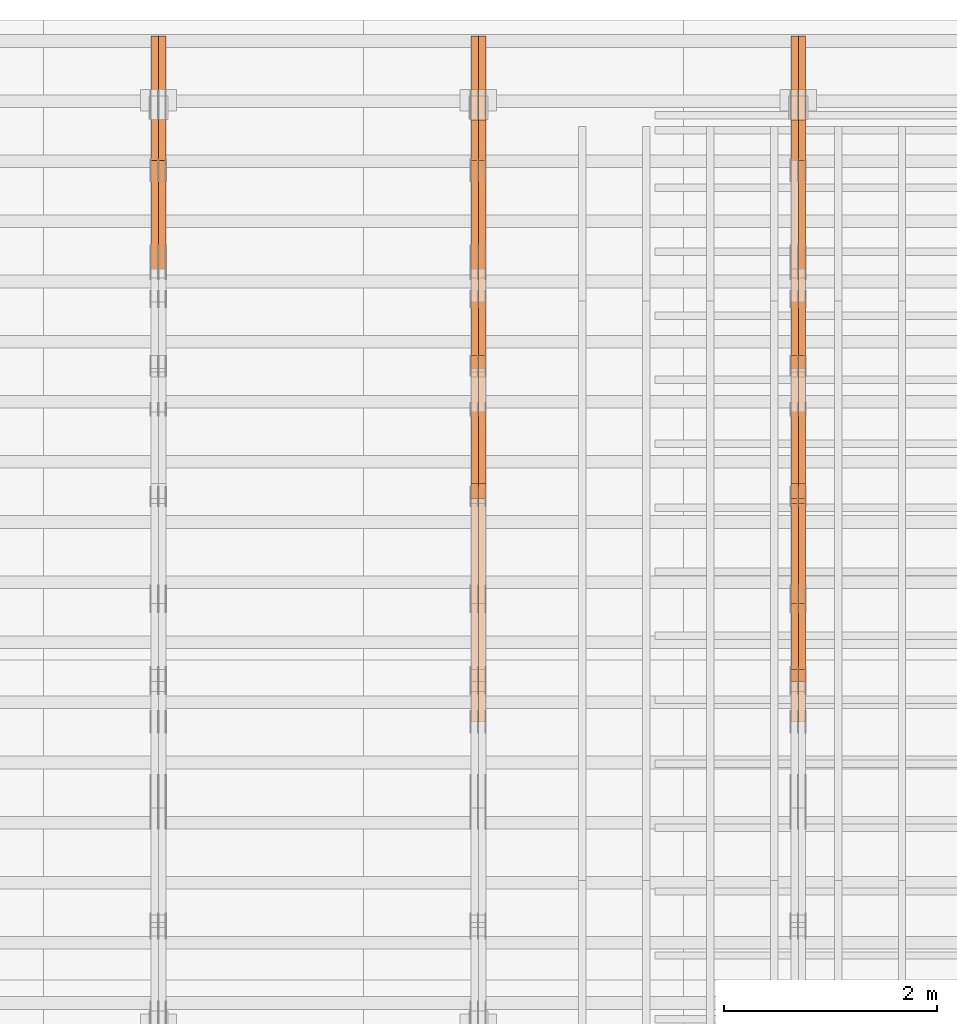
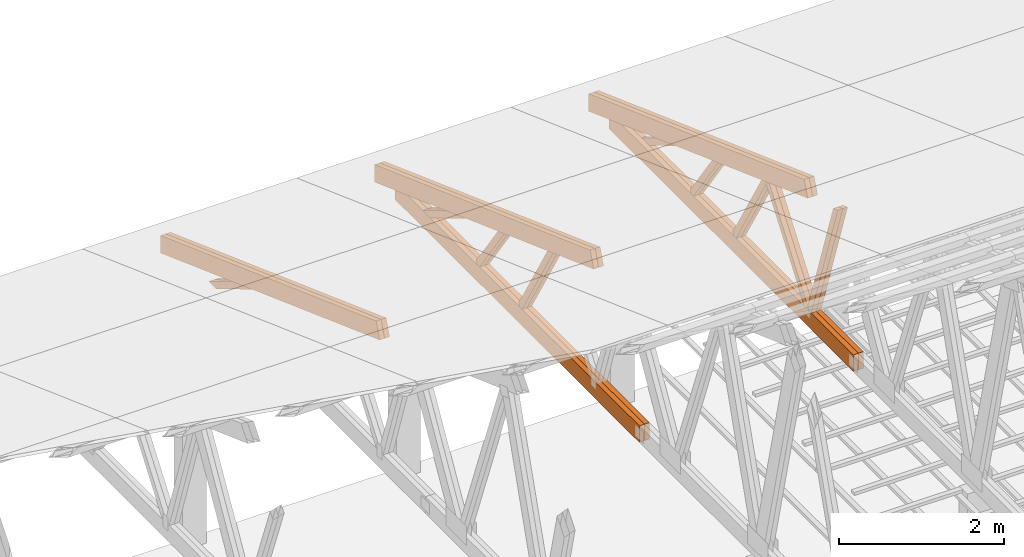
# One storey, part 63 of 189: 27 proxies.
"""IFC2X3 building model written with IfcOpenShell, lengths in millimetres."""

from ifc_helpers import new_model, entity, si_unit, converted_unit, derived_unit, direction, frame, origin, place, context, subcontext, project, spatial, polyline, outline, extrude, source, transform, mapped, material, type_object, type_shapes, element, save


model = new_model("IFC2X3")

# Units and contexts
model_context = context("Model", 3, precision=0.01, world=origin(), true_north=direction((6.12303176911189e-17, 1.0)))
body_context = subcontext(model_context, "Body", "Model", "MODEL_VIEW")
ifc_project = project(units=[si_unit("LENGTHUNIT", "METRE", prefix="MILLI"), si_unit("AREAUNIT", "SQUARE_METRE"), si_unit("VOLUMEUNIT", "CUBIC_METRE"), converted_unit("PLANEANGLEUNIT", "DEGREE", entity("IfcRatioMeasure", 0.0174532925199433), si_unit("PLANEANGLEUNIT", "RADIAN"), dimensions=[0, 0, 0, 0, 0, 0, 0]), si_unit("MASSUNIT", "GRAM", prefix="KILO"), derived_unit("MASSDENSITYUNIT", [(si_unit("MASSUNIT", "GRAM", prefix="KILO"), 1), (si_unit("LENGTHUNIT", "METRE"), -3)]), si_unit("TIMEUNIT", "SECOND"), si_unit("FREQUENCYUNIT", "HERTZ"), si_unit("THERMODYNAMICTEMPERATUREUNIT", "DEGREE_CELSIUS"), derived_unit("THERMALTRANSMITTANCEUNIT", [(si_unit("MASSUNIT", "GRAM", prefix="KILO"), 1), (si_unit("THERMODYNAMICTEMPERATUREUNIT", "KELVIN"), -1), (si_unit("TIMEUNIT", "SECOND"), -3)]), derived_unit("VOLUMETRICFLOWRATEUNIT", [(si_unit("LENGTHUNIT", "METRE"), 3), (si_unit("TIMEUNIT", "SECOND"), -1)]), si_unit("ELECTRICCURRENTUNIT", "AMPERE"), si_unit("ELECTRICVOLTAGEUNIT", "VOLT"), si_unit("POWERUNIT", "WATT"), si_unit("FORCEUNIT", "NEWTON"), si_unit("ILLUMINANCEUNIT", "LUX"), si_unit("LUMINOUSFLUXUNIT", "LUMEN"), si_unit("LUMINOUSINTENSITYUNIT", "CANDELA"), derived_unit("USERDEFINED", [(si_unit("MASSUNIT", "GRAM", prefix="KILO"), -1), (si_unit("LENGTHUNIT", "METRE"), -2), (si_unit("TIMEUNIT", "SECOND"), 3), (si_unit("LUMINOUSFLUXUNIT", "LUMEN"), 1)]), derived_unit("LINEARVELOCITYUNIT", [(si_unit("LENGTHUNIT", "METRE"), 1), (si_unit("TIMEUNIT", "SECOND"), -1)]), si_unit("PRESSUREUNIT", "PASCAL"), derived_unit("USERDEFINED", [(si_unit("LENGTHUNIT", "METRE"), -2), (si_unit("MASSUNIT", "GRAM", prefix="KILO"), 1), (si_unit("TIMEUNIT", "SECOND"), -2)])], contexts=[model_context])

# Site, building, storey
site_placement = place(None, origin())
site = spatial("IfcSite", under=ifc_project, at=site_placement, CompositionType="ELEMENT")
building_placement = place(site_placement, origin())
building = spatial("IfcBuilding", under=site, at=building_placement, CompositionType="ELEMENT")
storey_placement = place(building_placement, origin())
storey = spatial("IfcBuildingStorey", under=building, at=storey_placement, Name="Default", CompositionType="ELEMENT", Elevation=0.0)

# Proxies
ifc_material_1 = material(Name="IfcSurfaceStyle #240080")
building_element_proxy_type_1 = type_object("IfcBuildingElementProxyType", Name="T1-W9 240078", PredefinedType="NOTDEFINED", material=ifc_material_1)
shared_shape_1 = source(origin(), body_context, "Body", "SweptSolid", [
    extrude(outline(polyline([(-1151.44310138162, -47.5000079487596), (776.329826327547, -47.5000079487596), (809.267611644053, -8.1966354137375e-07), (793.242530238244, 47.5000083585914), (-1227.39686682822, 47.5000083585914), (-1151.44310138162, -47.5000079487596)])), frame((809.267685789073, 47.5000083585914, 0.0), z_axis=(0.0, 0.0, 1.0), x_axis=(-1.0, 0.0, 0.0)), (0.0, 0.0, 1.0), 69.9999999999999),
])
type_shapes(building_element_proxy_type_1, [shared_shape_1])
proxy_1_placement = place(building_placement, frame((45300.0, 24600.2198992919, 229.815691184017), z_axis=(-1.0, 0.0, 0.0), x_axis=(0.0, -0.31966811847134, 0.947529574226047)))
element("IfcBuildingElementProxy", 1, at=proxy_1_placement, inside=storey, type_object=building_element_proxy_type_1, material=ifc_material_1, Name="T1-W9", context=body_context, shape_type="MappedRepresentation", body=[
    mapped(shared_shape_1, transform((0.0, 0.0, 0.0), scale=1.0)),
])
ifc_material_2 = material(Name="IfcSurfaceStyle #240014")
building_element_proxy_type_2 = type_object("IfcBuildingElementProxyType", Name="T1-W9 240012", PredefinedType="NOTDEFINED", material=ifc_material_2)
shared_shape_2 = source(origin(), body_context, "Body", "SweptSolid", [
    extrude(outline(polyline([(-1151.44310138162, -47.5000079487596), (776.329826327547, -47.5000079487596), (809.267611644053, -8.1966354137375e-07), (793.242530238244, 47.5000083585914), (-1227.39686682822, 47.5000083585914), (-1151.44310138162, -47.5000079487596)])), frame((809.267685789073, 47.5000083585914, 0.0), z_axis=(0.0, 0.0, 1.0), x_axis=(-1.0, 0.0, 0.0)), (0.0, 0.0, 1.0), 69.9999999999999),
])
type_shapes(building_element_proxy_type_2, [shared_shape_2])
proxy_2_placement = place(building_placement, frame((45230.0, 24600.2198992919, 229.815691184017), z_axis=(-1.0, 0.0, 0.0), x_axis=(0.0, -0.31966811847134, 0.947529574226047)))
element("IfcBuildingElementProxy", 2, at=proxy_2_placement, inside=storey, type_object=building_element_proxy_type_2, material=ifc_material_2, Name="T1-W9", context=body_context, shape_type="MappedRepresentation", body=[
    mapped(shared_shape_2, transform((0.0, 0.0, 0.0), scale=1.0)),
])
ifc_material_3 = material(Name="IfcSurfaceStyle #239816")
building_element_proxy_type_3 = type_object("IfcBuildingElementProxyType", Name="T1-W10 239814", PredefinedType="NOTDEFINED", material=ifc_material_3)
shared_shape_3 = source(origin(), body_context, "Body", "SweptSolid", [
    extrude(outline(polyline([(-993.240970354386, -47.5000757607337), (635.890952815036, -47.5000757607337), (650.068145237537, -1.47580554758164e-05), (629.921374092803, 47.5000831397614), (-922.639501790989, 47.5000831397614), (-993.240970354386, -47.5000757607337)])), frame((650.068173419645, 47.5002811208496, 0.0), z_axis=(0.0, 0.0, 1.0), x_axis=(-1.0, 0.0, 0.0)), (0.0, 0.0, 1.0), 69.9999999999999),
])
type_shapes(building_element_proxy_type_3, [shared_shape_3])
proxy_3_placement = place(building_placement, frame((45300.0, 25701.688098798, 1507.2920009025), z_axis=(-1.0, 0.0, 0.0), x_axis=(0.0, -0.596486092002004, -0.802623412347395)))
element("IfcBuildingElementProxy", 3, at=proxy_3_placement, inside=storey, type_object=building_element_proxy_type_3, material=ifc_material_3, Name="T1-W10", context=body_context, shape_type="MappedRepresentation", body=[
    mapped(shared_shape_3, transform((0.0, 0.0, 0.0), scale=1.0)),
])
ifc_material_4 = material(Name="IfcSurfaceStyle #239750")
building_element_proxy_type_4 = type_object("IfcBuildingElementProxyType", Name="T1-W10 239748", PredefinedType="NOTDEFINED", material=ifc_material_4)
shared_shape_4 = source(origin(), body_context, "Body", "SweptSolid", [
    extrude(outline(polyline([(-993.240970354386, -47.5000757607337), (635.890952815036, -47.5000757607337), (650.068145237537, -1.47580554758164e-05), (629.921374092803, 47.5000831397614), (-922.639501790989, 47.5000831397614), (-993.240970354386, -47.5000757607337)])), frame((650.068173419645, 47.5002811208496, 0.0), z_axis=(0.0, 0.0, 1.0), x_axis=(-1.0, 0.0, 0.0)), (0.0, 0.0, 1.0), 69.9999999999999),
])
type_shapes(building_element_proxy_type_4, [shared_shape_4])
proxy_4_placement = place(building_placement, frame((45230.0, 25701.688098798, 1507.2920009025), z_axis=(-1.0, 0.0, 0.0), x_axis=(0.0, -0.596486092002004, -0.802623412347395)))
element("IfcBuildingElementProxy", 4, at=proxy_4_placement, inside=storey, type_object=building_element_proxy_type_4, material=ifc_material_4, Name="T1-W10", context=body_context, shape_type="MappedRepresentation", body=[
    mapped(shared_shape_4, transform((0.0, 0.0, 0.0), scale=1.0)),
])
ifc_material_5 = material(Name="IfcSurfaceStyle #239552")
building_element_proxy_type_5 = type_object("IfcBuildingElementProxyType", Name="T1-W11 239550", PredefinedType="NOTDEFINED", material=ifc_material_5)
shared_shape_5 = source(origin(), body_context, "Body", "SweptSolid", [
    extrude(outline(polyline([(-809.410890003667, -47.5000077306544), (561.624013869753, -47.5000077306544), (599.944137054867, -7.52294285037536e-05), (572.078784657538, 47.5000453453687), (-924.236045578491, 47.5000453453687), (-809.410890003667, -47.5000077306544)])), frame((599.944137054867, 47.5000453453687, 0.0), z_axis=(0.0, 0.0, 1.0), x_axis=(-1.0, 0.0, 0.0)), (0.0, 0.0, 1.0), 69.9999999999999),
])
type_shapes(building_element_proxy_type_5, [shared_shape_5])
proxy_5_placement = place(building_placement, frame((45300.0, 26434.7921369083, 220.965133687368), z_axis=(-1.0, 0.0, 0.0), x_axis=(0.0, -0.505995901100603, 0.862535882192381)))
element("IfcBuildingElementProxy", 5, at=proxy_5_placement, inside=storey, type_object=building_element_proxy_type_5, material=ifc_material_5, Name="T1-W11", context=body_context, shape_type="MappedRepresentation", body=[
    mapped(shared_shape_5, transform((0.0, 0.0, 0.0), scale=1.0)),
])
ifc_material_6 = material(Name="IfcSurfaceStyle #239486")
building_element_proxy_type_6 = type_object("IfcBuildingElementProxyType", Name="T1-W11 239484", PredefinedType="NOTDEFINED", material=ifc_material_6)
shared_shape_6 = source(origin(), body_context, "Body", "SweptSolid", [
    extrude(outline(polyline([(-809.410890003667, -47.5000077306544), (561.624013869753, -47.5000077306544), (599.944137054867, -7.52294285037536e-05), (572.078784657538, 47.5000453453687), (-924.236045578491, 47.5000453453687), (-809.410890003667, -47.5000077306544)])), frame((599.944137054867, 47.5000453453687, 0.0), z_axis=(0.0, 0.0, 1.0), x_axis=(-1.0, 0.0, 0.0)), (0.0, 0.0, 1.0), 69.9999999999999),
])
type_shapes(building_element_proxy_type_6, [shared_shape_6])
proxy_6_placement = place(building_placement, frame((45230.0, 26434.7921369083, 220.965133687368), z_axis=(-1.0, 0.0, 0.0), x_axis=(0.0, -0.505995901100603, 0.862535882192381)))
element("IfcBuildingElementProxy", 6, at=proxy_6_placement, inside=storey, type_object=building_element_proxy_type_6, material=ifc_material_6, Name="T1-W11", context=body_context, shape_type="MappedRepresentation", body=[
    mapped(shared_shape_6, transform((0.0, 0.0, 0.0), scale=1.0)),
])
ifc_material_7 = material(Name="IfcSurfaceStyle #239024")
building_element_proxy_type_7 = type_object("IfcBuildingElementProxyType", Name="T1-W13 239022", PredefinedType="NOTDEFINED", material=ifc_material_7)
shared_shape_7 = source(origin(), body_context, "Body", "SweptSolid", [
    extrude(outline(polyline([(-527.416466728212, -47.5000272833949), (387.658053197984, -47.5000272833949), (418.029495084182, -7.96824534414764e-06), (384.779443025059, 47.5000312675175), (-663.050524579013, 47.5000312675176), (-527.416466728212, -47.5000272833949)])), frame((418.029495084182, 47.5000671658844, 0.0), z_axis=(0.0, 0.0, 1.0), x_axis=(-1.0, 0.0, 0.0)), (0.0, 0.0, 1.0), 69.9999999999999),
])
type_shapes(building_element_proxy_type_7, [shared_shape_7])
proxy_7_placement = place(building_placement, frame((45300.0, 27471.0085508293, 217.760482033818), z_axis=(-1.0, 0.0, 0.0), x_axis=(0.0, -0.573462629043498, 0.819231721242848)))
element("IfcBuildingElementProxy", 7, at=proxy_7_placement, inside=storey, type_object=building_element_proxy_type_7, material=ifc_material_7, Name="T1-W13", context=body_context, shape_type="MappedRepresentation", body=[
    mapped(shared_shape_7, transform((0.0, 0.0, 0.0), scale=1.0)),
])
ifc_material_8 = material(Name="IfcSurfaceStyle #238958")
building_element_proxy_type_8 = type_object("IfcBuildingElementProxyType", Name="T1-W13 238956", PredefinedType="NOTDEFINED", material=ifc_material_8)
shared_shape_8 = source(origin(), body_context, "Body", "SweptSolid", [
    extrude(outline(polyline([(-527.416466728212, -47.5000272833949), (387.658053197984, -47.5000272833949), (418.029495084182, -7.96824534414764e-06), (384.779443025059, 47.5000312675175), (-663.050524579013, 47.5000312675176), (-527.416466728212, -47.5000272833949)])), frame((418.029495084182, 47.5000671658844, 0.0), z_axis=(0.0, 0.0, 1.0), x_axis=(-1.0, 0.0, 0.0)), (0.0, 0.0, 1.0), 69.9999999999999),
])
type_shapes(building_element_proxy_type_8, [shared_shape_8])
proxy_8_placement = place(building_placement, frame((45230.0, 27471.0085508293, 217.760482033818), z_axis=(-1.0, 0.0, 0.0), x_axis=(0.0, -0.573462629043498, 0.819231721242848)))
element("IfcBuildingElementProxy", 8, at=proxy_8_placement, inside=storey, type_object=building_element_proxy_type_8, material=ifc_material_8, Name="T1-W13", context=body_context, shape_type="MappedRepresentation", body=[
    mapped(shared_shape_8, transform((0.0, 0.0, 0.0), scale=1.0)),
])
ifc_material_9 = material(Name="IfcSurfaceStyle #238514")
building_element_proxy_type_9 = type_object("IfcBuildingElementProxyType", Name="T1-W12 238512", PredefinedType="NOTDEFINED", material=ifc_material_9)
shared_shape_9 = source(origin(), body_context, "Body", "SweptSolid", [
    extrude(outline(polyline([(-176.861423449428, -47.5000064161489), (503.856777435794, -47.5000064161489), (344.893496040196, 47.5000064161489), (-671.888850026563, 47.5000064161488), (-176.861423449428, -47.5000064161489)])), frame((503.856799890979, 47.5000428456028, 0.0), z_axis=(0.0, 0.0, 1.0), x_axis=(-1.0, 0.0, 0.0)), (0.0, 0.0, 1.0), 69.9999999999999),
])
type_shapes(building_element_proxy_type_9, [shared_shape_9])
proxy_9_placement = place(building_placement, frame((45300.0, 28785.6842742264, 163.452728724015), z_axis=(-1.0, 0.0, 0.0), x_axis=(0.0, -0.858392121304013, 0.51299411895576)))
element("IfcBuildingElementProxy", 9, at=proxy_9_placement, inside=storey, type_object=building_element_proxy_type_9, material=ifc_material_9, Name="T1-W12", context=body_context, shape_type="MappedRepresentation", body=[
    mapped(shared_shape_9, transform((0.0, 0.0, 0.0), scale=1.0)),
])
ifc_material_10 = material(Name="IfcSurfaceStyle #238400")
building_element_proxy_type_10 = type_object("IfcBuildingElementProxyType", Name="T1-B1 238398", PredefinedType="NOTDEFINED", material=ifc_material_10)
shared_shape_10 = source(origin(), body_context, "Body", "SweptSolid", [
    extrude(outline(polyline([(-2430.09461669922, -125.855288696288), (3499.90538330078, -125.855288696288), (3499.90538330078, 119.144711303711), (-2139.62153320312, 119.144711303711), (-2430.09461669922, 13.4211547851552), (-2430.09461669922, -125.855288696288)])), frame((3499.90538330078, 119.144711303711, 0.0), z_axis=(0.0, 0.0, 1.0), x_axis=(-1.0, 0.0, 0.0)), (0.0, 0.0, 1.0), 69.9999999999996),
])
type_shapes(building_element_proxy_type_10, [shared_shape_10])
proxy_10_placement = place(building_placement, frame((45300.0, 23570.0, 245.0), z_axis=(-1.0, 0.0, 0.0), x_axis=(0.0, 1.0, 0.0)))
element("IfcBuildingElementProxy", 10, at=proxy_10_placement, inside=storey, type_object=building_element_proxy_type_10, material=ifc_material_10, Name="T1-B1", context=body_context, shape_type="MappedRepresentation", body=[
    mapped(shared_shape_10, transform((0.0, 0.0, 0.0), scale=1.0)),
])
ifc_material_11 = material(Name="IfcSurfaceStyle #238334")
building_element_proxy_type_11 = type_object("IfcBuildingElementProxyType", Name="T1-B1 238332", PredefinedType="NOTDEFINED", material=ifc_material_11)
shared_shape_11 = source(origin(), body_context, "Body", "SweptSolid", [
    extrude(outline(polyline([(-2430.09461669922, -125.855288696288), (3499.90538330078, -125.855288696288), (3499.90538330078, 119.144711303711), (-2139.62153320312, 119.144711303711), (-2430.09461669922, 13.4211547851552), (-2430.09461669922, -125.855288696288)])), frame((3499.90538330078, 119.144711303711, 0.0), z_axis=(0.0, 0.0, 1.0), x_axis=(-1.0, 0.0, 0.0)), (0.0, 0.0, 1.0), 69.9999999999996),
])
type_shapes(building_element_proxy_type_11, [shared_shape_11])
proxy_11_placement = place(building_placement, frame((45230.0, 23570.0, 245.0), z_axis=(-1.0, 0.0, 0.0), x_axis=(0.0, 1.0, 0.0)))
element("IfcBuildingElementProxy", 11, at=proxy_11_placement, inside=storey, type_object=building_element_proxy_type_11, material=ifc_material_11, Name="T1-B1", context=body_context, shape_type="MappedRepresentation", body=[
    mapped(shared_shape_11, transform((0.0, 0.0, 0.0), scale=1.0)),
])
ifc_material_12 = material(Name="IfcSurfaceStyle #237110")
building_element_proxy_type_12 = type_object("IfcBuildingElementProxyType", Name="T1-T2 237108", PredefinedType="NOTDEFINED", material=ifc_material_12)
shared_shape_12 = source(origin(), body_context, "Body", "SweptSolid", [
    extrude(outline(polyline([(-2807.70681121203, -122.500041939424), (2763.12044548192, -122.500041939424), (2852.29315104137, 122.500041939424), (-2807.70678531126, 122.500041939424), (-2807.70681121203, -122.500041939424)])), frame((2852.29315104137, 122.500041939424, 0.0), z_axis=(0.0, 0.0, 1.0), x_axis=(-1.0, 0.0, 0.0)), (0.0, 0.0, 1.0), 69.9999999999997),
])
type_shapes(building_element_proxy_type_12, [shared_shape_12])
proxy_12_placement = place(building_placement, frame((45300.0, 30000.0, -42.7086715698242), z_axis=(-1.0, 0.0, 0.0), x_axis=(0.0, -0.939692620785908, 0.342020143325669)))
element("IfcBuildingElementProxy", 12, at=proxy_12_placement, inside=storey, type_object=building_element_proxy_type_12, material=ifc_material_12, Name="T1-T2", context=body_context, shape_type="MappedRepresentation", body=[
    mapped(shared_shape_12, transform((0.0, 0.0, 0.0), scale=1.0)),
])
ifc_material_13 = material(Name="IfcSurfaceStyle #237053")
building_element_proxy_type_13 = type_object("IfcBuildingElementProxyType", Name="T1-T2 237051", PredefinedType="NOTDEFINED", material=ifc_material_13)
shared_shape_13 = source(origin(), body_context, "Body", "SweptSolid", [
    extrude(outline(polyline([(-2807.70681121203, -122.500041939424), (2763.12044548192, -122.500041939424), (2852.29315104137, 122.500041939424), (-2807.70678531126, 122.500041939424), (-2807.70681121203, -122.500041939424)])), frame((2852.29315104137, 122.500041939424, 0.0), z_axis=(0.0, 0.0, 1.0), x_axis=(-1.0, 0.0, 0.0)), (0.0, 0.0, 1.0), 69.9999999999997),
])
type_shapes(building_element_proxy_type_13, [shared_shape_13])
proxy_13_placement = place(building_placement, frame((45230.0, 30000.0, -42.7086715698242), z_axis=(-1.0, 0.0, 0.0), x_axis=(0.0, -0.939692620785908, 0.342020143325669)))
element("IfcBuildingElementProxy", 13, at=proxy_13_placement, inside=storey, type_object=building_element_proxy_type_13, material=ifc_material_13, Name="T1-T2", context=body_context, shape_type="MappedRepresentation", body=[
    mapped(shared_shape_13, transform((0.0, 0.0, 0.0), scale=1.0)),
])
ifc_material_14 = material(Name="IfcSurfaceStyle #223762")
building_element_proxy_type_14 = type_object("IfcBuildingElementProxyType", Name="T1-W11 223760", PredefinedType="NOTDEFINED", material=ifc_material_14)
shared_shape_14 = source(origin(), body_context, "Body", "SweptSolid", [
    extrude(outline(polyline([(-809.410890003667, -47.5000077306544), (561.624013869753, -47.5000077306544), (599.944137054867, -7.52294285037536e-05), (572.078784657538, 47.5000453453687), (-924.236045578491, 47.5000453453687), (-809.410890003667, -47.5000077306544)])), frame((599.944137054867, 47.5000453453687, 0.0), z_axis=(0.0, 0.0, 1.0), x_axis=(-1.0, 0.0, 0.0)), (0.0, 0.0, 1.0), 69.9999999999999),
])
type_shapes(building_element_proxy_type_14, [shared_shape_14])
proxy_14_placement = place(building_placement, frame((42300.0, 26434.7921369083, 220.965133687368), z_axis=(-1.0, 0.0, 0.0), x_axis=(0.0, -0.505995901100603, 0.862535882192381)))
element("IfcBuildingElementProxy", 14, at=proxy_14_placement, inside=storey, type_object=building_element_proxy_type_14, material=ifc_material_14, Name="T1-W11", context=body_context, shape_type="MappedRepresentation", body=[
    mapped(shared_shape_14, transform((0.0, 0.0, 0.0), scale=1.0)),
])
ifc_material_15 = material(Name="IfcSurfaceStyle #223696")
building_element_proxy_type_15 = type_object("IfcBuildingElementProxyType", Name="T1-W11 223694", PredefinedType="NOTDEFINED", material=ifc_material_15)
shared_shape_15 = source(origin(), body_context, "Body", "SweptSolid", [
    extrude(outline(polyline([(-809.410890003667, -47.5000077306544), (561.624013869753, -47.5000077306544), (599.944137054867, -7.52294285037536e-05), (572.078784657538, 47.5000453453687), (-924.236045578491, 47.5000453453687), (-809.410890003667, -47.5000077306544)])), frame((599.944137054867, 47.5000453453687, 0.0), z_axis=(0.0, 0.0, 1.0), x_axis=(-1.0, 0.0, 0.0)), (0.0, 0.0, 1.0), 69.9999999999999),
])
type_shapes(building_element_proxy_type_15, [shared_shape_15])
proxy_15_placement = place(building_placement, frame((42230.0, 26434.7921369083, 220.965133687368), z_axis=(-1.0, 0.0, 0.0), x_axis=(0.0, -0.505995901100603, 0.862535882192381)))
element("IfcBuildingElementProxy", 15, at=proxy_15_placement, inside=storey, type_object=building_element_proxy_type_15, material=ifc_material_15, Name="T1-W11", context=body_context, shape_type="MappedRepresentation", body=[
    mapped(shared_shape_15, transform((0.0, 0.0, 0.0), scale=1.0)),
])
ifc_material_16 = material(Name="IfcSurfaceStyle #223234")
building_element_proxy_type_16 = type_object("IfcBuildingElementProxyType", Name="T1-W13 223232", PredefinedType="NOTDEFINED", material=ifc_material_16)
shared_shape_16 = source(origin(), body_context, "Body", "SweptSolid", [
    extrude(outline(polyline([(-527.416466728212, -47.5000272833949), (387.658053197984, -47.5000272833949), (418.029495084182, -7.96824534414764e-06), (384.779443025059, 47.5000312675175), (-663.050524579013, 47.5000312675176), (-527.416466728212, -47.5000272833949)])), frame((418.029495084182, 47.5000671658844, 0.0), z_axis=(0.0, 0.0, 1.0), x_axis=(-1.0, 0.0, 0.0)), (0.0, 0.0, 1.0), 69.9999999999999),
])
type_shapes(building_element_proxy_type_16, [shared_shape_16])
proxy_16_placement = place(building_placement, frame((42300.0, 27471.0085508293, 217.760482033818), z_axis=(-1.0, 0.0, 0.0), x_axis=(0.0, -0.573462629043498, 0.819231721242848)))
element("IfcBuildingElementProxy", 16, at=proxy_16_placement, inside=storey, type_object=building_element_proxy_type_16, material=ifc_material_16, Name="T1-W13", context=body_context, shape_type="MappedRepresentation", body=[
    mapped(shared_shape_16, transform((0.0, 0.0, 0.0), scale=1.0)),
])
ifc_material_17 = material(Name="IfcSurfaceStyle #223168")
building_element_proxy_type_17 = type_object("IfcBuildingElementProxyType", Name="T1-W13 223166", PredefinedType="NOTDEFINED", material=ifc_material_17)
shared_shape_17 = source(origin(), body_context, "Body", "SweptSolid", [
    extrude(outline(polyline([(-527.416466728212, -47.5000272833949), (387.658053197984, -47.5000272833949), (418.029495084182, -7.96824534414764e-06), (384.779443025059, 47.5000312675175), (-663.050524579013, 47.5000312675176), (-527.416466728212, -47.5000272833949)])), frame((418.029495084182, 47.5000671658844, 0.0), z_axis=(0.0, 0.0, 1.0), x_axis=(-1.0, 0.0, 0.0)), (0.0, 0.0, 1.0), 69.9999999999999),
])
type_shapes(building_element_proxy_type_17, [shared_shape_17])
proxy_17_placement = place(building_placement, frame((42230.0, 27471.0085508293, 217.760482033818), z_axis=(-1.0, 0.0, 0.0), x_axis=(0.0, -0.573462629043498, 0.819231721242848)))
element("IfcBuildingElementProxy", 17, at=proxy_17_placement, inside=storey, type_object=building_element_proxy_type_17, material=ifc_material_17, Name="T1-W13", context=body_context, shape_type="MappedRepresentation", body=[
    mapped(shared_shape_17, transform((0.0, 0.0, 0.0), scale=1.0)),
])
ifc_material_18 = material(Name="IfcSurfaceStyle #222724")
building_element_proxy_type_18 = type_object("IfcBuildingElementProxyType", Name="T1-W12 222722", PredefinedType="NOTDEFINED", material=ifc_material_18)
shared_shape_18 = source(origin(), body_context, "Body", "SweptSolid", [
    extrude(outline(polyline([(-176.861423449428, -47.5000064161489), (503.856777435794, -47.5000064161489), (344.893496040196, 47.5000064161489), (-671.888850026563, 47.5000064161488), (-176.861423449428, -47.5000064161489)])), frame((503.856799890979, 47.5000428456028, 0.0), z_axis=(0.0, 0.0, 1.0), x_axis=(-1.0, 0.0, 0.0)), (0.0, 0.0, 1.0), 69.9999999999999),
])
type_shapes(building_element_proxy_type_18, [shared_shape_18])
proxy_18_placement = place(building_placement, frame((42300.0, 28785.6842742264, 163.452728724015), z_axis=(-1.0, 0.0, 0.0), x_axis=(0.0, -0.858392121304013, 0.51299411895576)))
element("IfcBuildingElementProxy", 18, at=proxy_18_placement, inside=storey, type_object=building_element_proxy_type_18, material=ifc_material_18, Name="T1-W12", context=body_context, shape_type="MappedRepresentation", body=[
    mapped(shared_shape_18, transform((0.0, 0.0, 0.0), scale=1.0)),
])
ifc_material_19 = material(Name="IfcSurfaceStyle #222667")
building_element_proxy_type_19 = type_object("IfcBuildingElementProxyType", Name="T1-W12 222665", PredefinedType="NOTDEFINED", material=ifc_material_19)
shared_shape_19 = source(origin(), body_context, "Body", "SweptSolid", [
    extrude(outline(polyline([(-176.861423449428, -47.5000064161489), (503.856777435794, -47.5000064161489), (344.893496040196, 47.5000064161489), (-671.888850026563, 47.5000064161488), (-176.861423449428, -47.5000064161489)])), frame((503.856799890979, 47.5000428456028, 0.0), z_axis=(0.0, 0.0, 1.0), x_axis=(-1.0, 0.0, 0.0)), (0.0, 0.0, 1.0), 69.9999999999999),
])
type_shapes(building_element_proxy_type_19, [shared_shape_19])
proxy_19_placement = place(building_placement, frame((42230.0, 28785.6842742264, 163.452728724015), z_axis=(-1.0, 0.0, 0.0), x_axis=(0.0, -0.858392121304013, 0.51299411895576)))
element("IfcBuildingElementProxy", 19, at=proxy_19_placement, inside=storey, type_object=building_element_proxy_type_19, material=ifc_material_19, Name="T1-W12", context=body_context, shape_type="MappedRepresentation", body=[
    mapped(shared_shape_19, transform((0.0, 0.0, 0.0), scale=1.0)),
])
ifc_material_20 = material(Name="IfcSurfaceStyle #222610")
building_element_proxy_type_20 = type_object("IfcBuildingElementProxyType", Name="T1-B1 222608", PredefinedType="NOTDEFINED", material=ifc_material_20)
shared_shape_20 = source(origin(), body_context, "Body", "SweptSolid", [
    extrude(outline(polyline([(-2430.09461669922, -125.855288696288), (3499.90538330078, -125.855288696288), (3499.90538330078, 119.144711303711), (-2139.62153320312, 119.144711303711), (-2430.09461669922, 13.4211547851552), (-2430.09461669922, -125.855288696288)])), frame((3499.90538330078, 119.144711303711, 0.0), z_axis=(0.0, 0.0, 1.0), x_axis=(-1.0, 0.0, 0.0)), (0.0, 0.0, 1.0), 69.9999999999996),
])
type_shapes(building_element_proxy_type_20, [shared_shape_20])
proxy_20_placement = place(building_placement, frame((42300.0, 23570.0, 245.0), z_axis=(-1.0, 0.0, 0.0), x_axis=(0.0, 1.0, 0.0)))
element("IfcBuildingElementProxy", 20, at=proxy_20_placement, inside=storey, type_object=building_element_proxy_type_20, material=ifc_material_20, Name="T1-B1", context=body_context, shape_type="MappedRepresentation", body=[
    mapped(shared_shape_20, transform((0.0, 0.0, 0.0), scale=1.0)),
])
ifc_material_21 = material(Name="IfcSurfaceStyle #222544")
building_element_proxy_type_21 = type_object("IfcBuildingElementProxyType", Name="T1-B1 222542", PredefinedType="NOTDEFINED", material=ifc_material_21)
shared_shape_21 = source(origin(), body_context, "Body", "SweptSolid", [
    extrude(outline(polyline([(-2430.09461669922, -125.855288696288), (3499.90538330078, -125.855288696288), (3499.90538330078, 119.144711303711), (-2139.62153320312, 119.144711303711), (-2430.09461669922, 13.4211547851552), (-2430.09461669922, -125.855288696288)])), frame((3499.90538330078, 119.144711303711, 0.0), z_axis=(0.0, 0.0, 1.0), x_axis=(-1.0, 0.0, 0.0)), (0.0, 0.0, 1.0), 69.9999999999996),
])
type_shapes(building_element_proxy_type_21, [shared_shape_21])
proxy_21_placement = place(building_placement, frame((42230.0, 23570.0, 245.0), z_axis=(-1.0, 0.0, 0.0), x_axis=(0.0, 1.0, 0.0)))
element("IfcBuildingElementProxy", 21, at=proxy_21_placement, inside=storey, type_object=building_element_proxy_type_21, material=ifc_material_21, Name="T1-B1", context=body_context, shape_type="MappedRepresentation", body=[
    mapped(shared_shape_21, transform((0.0, 0.0, 0.0), scale=1.0)),
])
ifc_material_22 = material(Name="IfcSurfaceStyle #221320")
building_element_proxy_type_22 = type_object("IfcBuildingElementProxyType", Name="T1-T2 221318", PredefinedType="NOTDEFINED", material=ifc_material_22)
shared_shape_22 = source(origin(), body_context, "Body", "SweptSolid", [
    extrude(outline(polyline([(-2807.70681121203, -122.500041939424), (2763.12044548192, -122.500041939424), (2852.29315104137, 122.500041939424), (-2807.70678531126, 122.500041939424), (-2807.70681121203, -122.500041939424)])), frame((2852.29315104137, 122.500041939424, 0.0), z_axis=(0.0, 0.0, 1.0), x_axis=(-1.0, 0.0, 0.0)), (0.0, 0.0, 1.0), 69.9999999999997),
])
type_shapes(building_element_proxy_type_22, [shared_shape_22])
proxy_22_placement = place(building_placement, frame((42300.0, 30000.0, -42.7086715698242), z_axis=(-1.0, 0.0, 0.0), x_axis=(0.0, -0.939692620785908, 0.342020143325669)))
element("IfcBuildingElementProxy", 22, at=proxy_22_placement, inside=storey, type_object=building_element_proxy_type_22, material=ifc_material_22, Name="T1-T2", context=body_context, shape_type="MappedRepresentation", body=[
    mapped(shared_shape_22, transform((0.0, 0.0, 0.0), scale=1.0)),
])
ifc_material_23 = material(Name="IfcSurfaceStyle #221263")
building_element_proxy_type_23 = type_object("IfcBuildingElementProxyType", Name="T1-T2 221261", PredefinedType="NOTDEFINED", material=ifc_material_23)
shared_shape_23 = source(origin(), body_context, "Body", "SweptSolid", [
    extrude(outline(polyline([(-2807.70681121203, -122.500041939424), (2763.12044548192, -122.500041939424), (2852.29315104137, 122.500041939424), (-2807.70678531126, 122.500041939424), (-2807.70681121203, -122.500041939424)])), frame((2852.29315104137, 122.500041939424, 0.0), z_axis=(0.0, 0.0, 1.0), x_axis=(-1.0, 0.0, 0.0)), (0.0, 0.0, 1.0), 69.9999999999997),
])
type_shapes(building_element_proxy_type_23, [shared_shape_23])
proxy_23_placement = place(building_placement, frame((42230.0, 30000.0, -42.7086715698242), z_axis=(-1.0, 0.0, 0.0), x_axis=(0.0, -0.939692620785908, 0.342020143325669)))
element("IfcBuildingElementProxy", 23, at=proxy_23_placement, inside=storey, type_object=building_element_proxy_type_23, material=ifc_material_23, Name="T1-T2", context=body_context, shape_type="MappedRepresentation", body=[
    mapped(shared_shape_23, transform((0.0, 0.0, 0.0), scale=1.0)),
])
ifc_material_24 = material(Name="IfcSurfaceStyle #206934")
building_element_proxy_type_24 = type_object("IfcBuildingElementProxyType", Name="T1-W12 206932", PredefinedType="NOTDEFINED", material=ifc_material_24)
shared_shape_24 = source(origin(), body_context, "Body", "SweptSolid", [
    extrude(outline(polyline([(-176.861423449428, -47.5000064161489), (503.856777435794, -47.5000064161489), (344.893496040196, 47.5000064161489), (-671.888850026563, 47.5000064161488), (-176.861423449428, -47.5000064161489)])), frame((503.856799890979, 47.5000428456028, 0.0), z_axis=(0.0, 0.0, 1.0), x_axis=(-1.0, 0.0, 0.0)), (0.0, 0.0, 1.0), 69.9999999999999),
])
type_shapes(building_element_proxy_type_24, [shared_shape_24])
proxy_24_placement = place(building_placement, frame((39300.0, 28785.6842742264, 163.452728724015), z_axis=(-1.0, 0.0, 0.0), x_axis=(0.0, -0.858392121304013, 0.51299411895576)))
element("IfcBuildingElementProxy", 24, at=proxy_24_placement, inside=storey, type_object=building_element_proxy_type_24, material=ifc_material_24, Name="T1-W12", context=body_context, shape_type="MappedRepresentation", body=[
    mapped(shared_shape_24, transform((0.0, 0.0, 0.0), scale=1.0)),
])
ifc_material_25 = material(Name="IfcSurfaceStyle #206877")
building_element_proxy_type_25 = type_object("IfcBuildingElementProxyType", Name="T1-W12 206875", PredefinedType="NOTDEFINED", material=ifc_material_25)
shared_shape_25 = source(origin(), body_context, "Body", "SweptSolid", [
    extrude(outline(polyline([(-176.861423449428, -47.5000064161489), (503.856777435794, -47.5000064161489), (344.893496040196, 47.5000064161489), (-671.888850026563, 47.5000064161488), (-176.861423449428, -47.5000064161489)])), frame((503.856799890979, 47.5000428456028, 0.0), z_axis=(0.0, 0.0, 1.0), x_axis=(-1.0, 0.0, 0.0)), (0.0, 0.0, 1.0), 69.9999999999999),
])
type_shapes(building_element_proxy_type_25, [shared_shape_25])
proxy_25_placement = place(building_placement, frame((39230.0, 28785.6842742264, 163.452728724015), z_axis=(-1.0, 0.0, 0.0), x_axis=(0.0, -0.858392121304013, 0.51299411895576)))
element("IfcBuildingElementProxy", 25, at=proxy_25_placement, inside=storey, type_object=building_element_proxy_type_25, material=ifc_material_25, Name="T1-W12", context=body_context, shape_type="MappedRepresentation", body=[
    mapped(shared_shape_25, transform((0.0, 0.0, 0.0), scale=1.0)),
])
ifc_material_26 = material(Name="IfcSurfaceStyle #205530")
building_element_proxy_type_26 = type_object("IfcBuildingElementProxyType", Name="T1-T2 205528", PredefinedType="NOTDEFINED", material=ifc_material_26)
shared_shape_26 = source(origin(), body_context, "Body", "SweptSolid", [
    extrude(outline(polyline([(-2807.70681121203, -122.500041939424), (2763.12044548192, -122.500041939424), (2852.29315104137, 122.500041939424), (-2807.70678531126, 122.500041939424), (-2807.70681121203, -122.500041939424)])), frame((2852.29315104137, 122.500041939424, 0.0), z_axis=(0.0, 0.0, 1.0), x_axis=(-1.0, 0.0, 0.0)), (0.0, 0.0, 1.0), 69.9999999999997),
])
type_shapes(building_element_proxy_type_26, [shared_shape_26])
proxy_26_placement = place(building_placement, frame((39300.0, 30000.0, -42.7086715698242), z_axis=(-1.0, 0.0, 0.0), x_axis=(0.0, -0.939692620785908, 0.342020143325669)))
element("IfcBuildingElementProxy", 26, at=proxy_26_placement, inside=storey, type_object=building_element_proxy_type_26, material=ifc_material_26, Name="T1-T2", context=body_context, shape_type="MappedRepresentation", body=[
    mapped(shared_shape_26, transform((0.0, 0.0, 0.0), scale=1.0)),
])
ifc_material_27 = material(Name="IfcSurfaceStyle #205473")
building_element_proxy_type_27 = type_object("IfcBuildingElementProxyType", Name="T1-T2 205471", PredefinedType="NOTDEFINED", material=ifc_material_27)
shared_shape_27 = source(origin(), body_context, "Body", "SweptSolid", [
    extrude(outline(polyline([(-2807.70681121203, -122.500041939424), (2763.12044548192, -122.500041939424), (2852.29315104137, 122.500041939424), (-2807.70678531126, 122.500041939424), (-2807.70681121203, -122.500041939424)])), frame((2852.29315104137, 122.500041939424, 0.0), z_axis=(0.0, 0.0, 1.0), x_axis=(-1.0, 0.0, 0.0)), (0.0, 0.0, 1.0), 69.9999999999997),
])
type_shapes(building_element_proxy_type_27, [shared_shape_27])
proxy_27_placement = place(building_placement, frame((39230.0, 30000.0, -42.7086715698242), z_axis=(-1.0, 0.0, 0.0), x_axis=(0.0, -0.939692620785908, 0.342020143325669)))
element("IfcBuildingElementProxy", 27, at=proxy_27_placement, inside=storey, type_object=building_element_proxy_type_27, material=ifc_material_27, Name="T1-T2", context=body_context, shape_type="MappedRepresentation", body=[
    mapped(shared_shape_27, transform((0.0, 0.0, 0.0), scale=1.0)),
])

save(model, "model.ifc")
